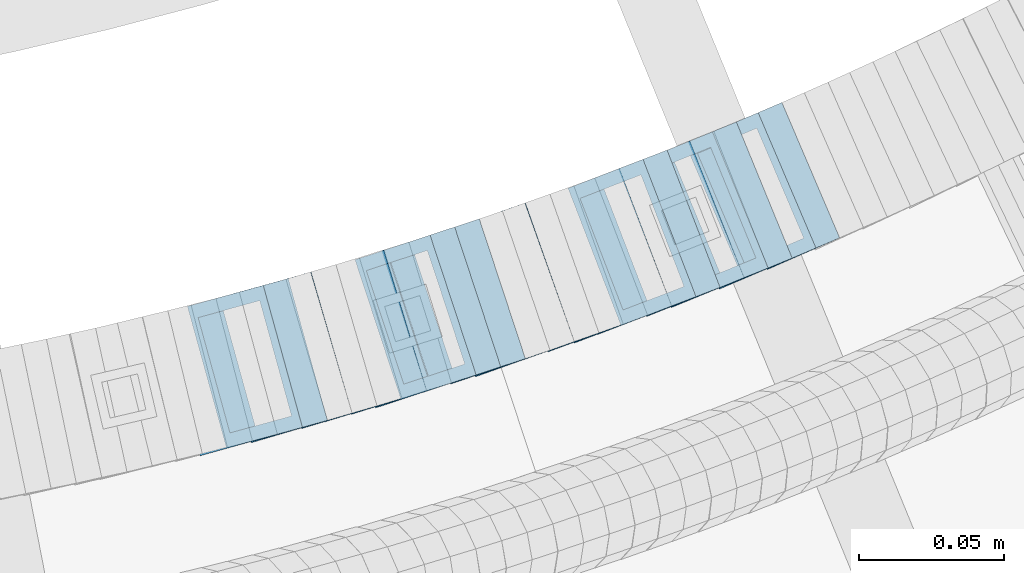
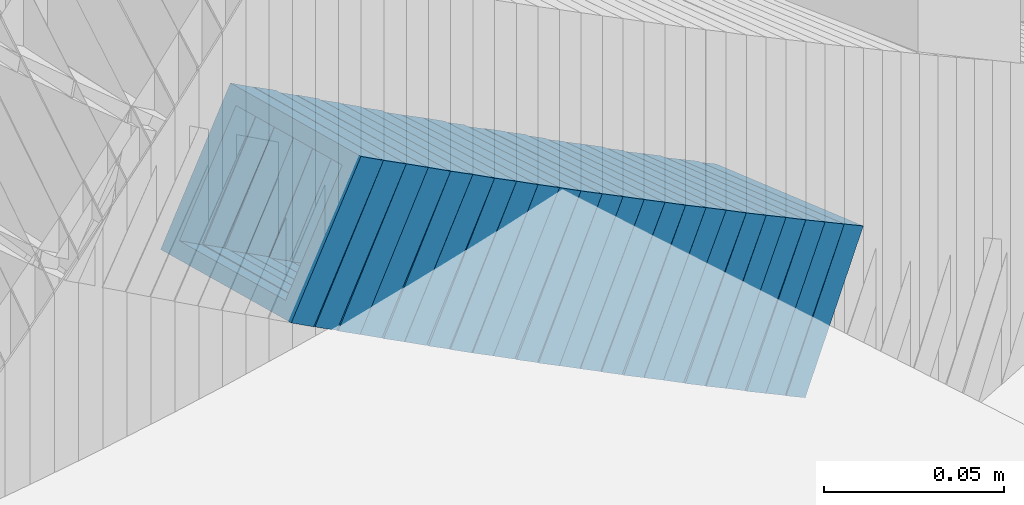
# One storey, part 712 of 975: 24 members.
"""IFC2X3 building model written with IfcOpenShell, lengths in millimetres."""

from ifc_helpers import new_model, si_unit, frame, origin_with_axes, place, context, subcontext, project, spatial, faceted_brep, material, type_object, element, save


model = new_model("IFC2X3")

# Units and contexts
model_context = context("Model", 3, precision=1e-05, world=origin_with_axes())
body_context = subcontext(model_context, "Body", "Model", "MODEL_VIEW")
ifc_project = project(units=[si_unit("LENGTHUNIT", "METRE", prefix="MILLI"), si_unit("AREAUNIT", "SQUARE_METRE"), si_unit("VOLUMEUNIT", "CUBIC_METRE"), si_unit("MASSUNIT", "GRAM", prefix="KILO"), si_unit("TIMEUNIT", "SECOND"), si_unit("PLANEANGLEUNIT", "RADIAN"), si_unit("SOLIDANGLEUNIT", "STERADIAN"), si_unit("THERMODYNAMICTEMPERATUREUNIT", "DEGREE_CELSIUS"), si_unit("LUMINOUSINTENSITYUNIT", "LUMEN")], contexts=[model_context])

# Site, building, storey
site_placement = place(None, origin_with_axes())
site = spatial("IfcSite", under=ifc_project, at=site_placement, CompositionType="ELEMENT")
building_placement = place(site_placement, origin_with_axes())
building = spatial("IfcBuilding", under=site, at=building_placement, Name="Undefined", CompositionType="ELEMENT")
storey_placement = place(building_placement, origin_with_axes())
storey = spatial("IfcBuildingStorey", under=building, at=storey_placement, Name="Undefined", CompositionType="ELEMENT", Elevation=0.0)

# Members
ifc_material = material()
member_type = type_object("IfcMemberType", Name="HSS2X2X.188_TUBES", PredefinedType="NOTDEFINED")
member_1_placement = place(storey_placement, frame((35093.8103006779, 2053.41983135916, 3047.19961551129), z_axis=(0.268798967764145, -0.963196301347202, 2.08201072382508e-10), x_axis=(-0.80773431354215, -0.22541422687225, 0.544751048691214)))
element("IfcMember", 1, at=member_1_placement, inside=storey, type_object=member_type, material=ifc_material, Name="WALL", ObjectType="HSS2X2X.188_TUBES", context=body_context, shape_type="Brep", body=[
    faceted_brep([(0.0, 20.6374999999753, -20.6375000000298), (0.0, -20.6375000000153, -20.6375000000153), (10.648004507897, -20.6374999999862, -20.637499999968), (10.6480045078188, 20.6374999999771, -20.6375000000808), (0.0, -20.6374999999825, 20.6375000000335), (10.6480045079406, -20.6374999999698, 20.6375000001062), (0.0, 20.6375000000116, 20.6375000000189), (10.6480045078679, 20.6374999999935, 20.6375000000007), (0.0, 25.3999999999724, -25.4000000000342), (0.0, 25.400000000016, 25.4000000000196), (10.6480045078661, 25.3999999999905, 25.4000000000015), (10.648004507806, 25.3999999999705, -25.4000000000997), (0.0, -25.399999999976, 25.4000000000378), (10.6480045079552, -25.3999999999633, 25.4000000001288), (0.0, -25.400000000016, -25.4000000000196), (10.6480045078988, -25.3999999999814, -25.3999999999651)], [[[0, 1, 2, 3]], [[1, 4, 5, 2]], [[4, 6, 7, 5]], [[6, 0, 3, 7]], [[8, 9, 10, 11]], [[9, 12, 13, 10]], [[12, 14, 15, 13]], [[14, 8, 11, 15]], [[13, 15, 11, 10], [5, 7, 3, 2]], [[14, 12, 9, 8], [6, 4, 1, 0]]]),
])
member_2_placement = place(storey_placement, frame((35102.8355591383, 2055.95242509423, 3041.32460536502), z_axis=(0.265928998080432, -0.963992618218593, -1.22554411063902e-11), x_axis=(-0.815044169709422, -0.224839770919824, 0.533994455809609)))
element("IfcMember", 2, at=member_2_placement, inside=storey, type_object=member_type, material=ifc_material, Name="WALL", ObjectType="HSS2X2X.188_TUBES", context=body_context, shape_type="Brep", body=[
    faceted_brep([(0.0, 20.6374999999753, -20.6375000000298), (0.0, -20.6375000000153, -20.6375000000153), (10.6709887076922, -20.6374999999844, -20.6374999999825), (10.6709887076995, 20.6375000000171, -20.6374999999753), (0.0, -20.6374999999825, 20.6375000000335), (10.6709887076922, -20.6374999999971, 20.6375000000153), (0.0, 20.6375000000116, 20.6375000000189), (10.6709887076941, 20.6375000000025, 20.6375000000189), (0.0, 25.3999999999724, -25.4000000000342), (0.0, 25.400000000016, 25.4000000000196), (10.6709887076959, 25.3999999999996, 25.4000000000233), (10.6709887077013, 25.4000000000178, -25.3999999999724), (0.0, -25.399999999976, 25.4000000000378), (10.6709887076904, -25.3999999999978, 25.400000000016), (0.0, -25.400000000016, -25.4000000000196), (10.6709887076959, -25.3999999999796, -25.3999999999796)], [[[0, 1, 2, 3]], [[1, 4, 5, 2]], [[4, 6, 7, 5]], [[6, 0, 3, 7]], [[8, 9, 10, 11]], [[9, 12, 13, 10]], [[12, 14, 15, 13]], [[14, 8, 11, 15]], [[13, 15, 11, 10], [5, 7, 3, 2]], [[14, 12, 9, 8], [6, 4, 1, 0]]]),
])
member_3_placement = place(storey_placement, frame((35110.8140978332, 2058.06413469108, 3035.73875214641), z_axis=(0.282166323550089, -0.959365501701112, 2.23427377932239e-10), x_axis=(-0.806820640951415, -0.237300187985733, 0.541044428967422)))
element("IfcMember", 3, at=member_3_placement, inside=storey, type_object=member_type, material=ifc_material, Name="WALL", ObjectType="HSS2X2X.188_TUBES", context=body_context, shape_type="Brep", body=[
    faceted_brep([(0.0, 20.6374999999753, -20.6375000000298), (0.0, -20.6375000000153, -20.6375000000153), (10.5422957651572, -20.6374999999771, -20.6374999999534), (10.5422957651481, 20.6375000000153, -20.6374999999789), (0.0, -20.6374999999825, 20.6375000000335), (10.5422957651535, -20.6374999999971, 20.6375000000298), (0.0, 20.6375000000116, 20.6375000000189), (10.5422957651444, 20.6374999999971, 20.6375000000044), (0.0, 25.3999999999724, -25.4000000000342), (0.0, 25.400000000016, 25.4000000000196), (10.5422957651426, 25.3999999999924, 25.3999999999905), (10.5422957651463, 25.4000000000178, -25.3999999999833), (0.0, -25.399999999976, 25.4000000000378), (10.5422957651499, -25.3999999999996, 25.4000000000269), (0.0, -25.400000000016, -25.4000000000196), (10.5422957651554, -25.3999999999742, -25.3999999999469)], [[[0, 1, 2, 3]], [[1, 4, 5, 2]], [[4, 6, 7, 5]], [[6, 0, 3, 7]], [[8, 9, 10, 11]], [[9, 12, 13, 10]], [[12, 14, 15, 13]], [[14, 8, 11, 15]], [[13, 15, 11, 10], [5, 7, 3, 2]], [[14, 12, 9, 8], [6, 4, 1, 0]]]),
])
member_4_placement = place(storey_placement, frame((35119.4169723431, 2060.61019087342, 3029.98028193762), z_axis=(0.279142363058039, -0.960249728532309, -1.20638560474617e-10), x_axis=(-0.805994231967301, -0.234300648990504, 0.543577504977965)))
element("IfcMember", 4, at=member_4_placement, inside=storey, type_object=member_type, material=ifc_material, Name="WALL", ObjectType="HSS2X2X.188_TUBES", context=body_context, shape_type="Brep", body=[
    faceted_brep([(0.0, 20.6374999999753, -20.6375000000298), (0.0, -20.6375000000153, -20.6375000000153), (10.6709887076922, -20.6374999999844, -20.6374999999825), (10.6709887076995, 20.6375000000171, -20.6374999999753), (0.0, -20.6374999999825, 20.6375000000335), (10.6709887076922, -20.6374999999971, 20.6375000000153), (0.0, 20.6375000000116, 20.6375000000189), (10.6709887076941, 20.6375000000025, 20.6375000000189), (0.0, 25.3999999999724, -25.4000000000342), (0.0, 25.400000000016, 25.4000000000196), (10.6709887076959, 25.3999999999996, 25.4000000000233), (10.6709887077013, 25.4000000000178, -25.3999999999724), (0.0, -25.399999999976, 25.4000000000378), (10.6709887076904, -25.3999999999978, 25.400000000016), (0.0, -25.400000000016, -25.4000000000196), (10.6709887076959, -25.3999999999796, -25.3999999999796)], [[[0, 1, 2, 3]], [[1, 4, 5, 2]], [[4, 6, 7, 5]], [[6, 0, 3, 7]], [[8, 9, 10, 11]], [[9, 12, 13, 10]], [[12, 14, 15, 13]], [[14, 8, 11, 15]], [[13, 15, 11, 10], [5, 7, 3, 2]], [[14, 12, 9, 8], [6, 4, 1, 0]]]),
])
member_5_placement = place(storey_placement, frame((35127.9898472608, 2063.04934262772, 3024.1522421416), z_axis=(0.289389501515281, -0.957211427226366, -2.71364569925936e-10), x_axis=(-0.808269248899405, -0.244360470969586, 0.535713338933346)))
element("IfcMember", 5, at=member_5_placement, inside=storey, type_object=member_type, material=ifc_material, Name="WALL", ObjectType="HSS2X2X.188_TUBES", context=body_context, shape_type="Brep", body=[
    faceted_brep([(0.0, 20.6374999999753, -20.6375000000298), (0.0, -20.6375000000153, -20.6375000000153), (10.6395488625676, -20.6374999999771, -20.6374999999716), (10.6395488625531, 20.6374999999916, -20.6375000000189), (0.0, -20.6374999999825, 20.6375000000335), (10.6395488625731, -20.6374999999844, 20.6375000000153), (0.0, 20.6375000000116, 20.6375000000189), (10.6395488625585, 20.6374999999825, 20.637499999968), (0.0, 25.3999999999724, -25.4000000000342), (0.0, 25.400000000016, 25.4000000000196), (10.6395488625567, 25.3999999999778, 25.3999999999614), (10.6395488625494, 25.3999999999887, -25.4000000000233), (0.0, -25.399999999976, 25.4000000000378), (10.6395488625749, -25.3999999999851, 25.400000000016), (0.0, -25.400000000016, -25.4000000000196), (10.6395488625658, -25.399999999976, -25.3999999999687)], [[[0, 1, 2, 3]], [[1, 4, 5, 2]], [[4, 6, 7, 5]], [[6, 0, 3, 7]], [[8, 9, 10, 11]], [[9, 12, 13, 10]], [[12, 14, 15, 13]], [[14, 8, 11, 15]], [[13, 15, 11, 10], [5, 7, 3, 2]], [[14, 12, 9, 8], [6, 4, 1, 0]]]),
])
member_6_placement = place(storey_placement, frame((35136.1624697946, 2065.50301785137, 3018.52795959015), z_axis=(0.292504341929598, -0.956264194640965, -2.45950104726944e-11), x_axis=(-0.800853960868517, -0.244967093959789, 0.546465054910288)))
element("IfcMember", 6, at=member_6_placement, inside=storey, type_object=member_type, material=ifc_material, Name="WALL", ObjectType="HSS2X2X.188_TUBES", context=body_context, shape_type="Brep", body=[
    faceted_brep([(0.0, 20.6374999999753, -20.6375000000298), (0.0, -20.6375000000153, -20.6375000000153), (10.6061303028146, -20.6374999999571, -20.6374999999643), (10.6061303027491, 20.6374999999971, -20.6375000000007), (0.0, -20.6374999999825, 20.6375000000335), (10.6061303027855, -20.6374999999825, 20.6375000000116), (0.0, 20.6375000000116, 20.6375000000189), (10.6061303027236, 20.637499999968, 20.6374999999716), (0.0, 25.3999999999724, -25.4000000000342), (0.0, 25.400000000016, 25.4000000000196), (10.6061303027163, 25.3999999999651, 25.3999999999651), (10.6061303027454, 25.3999999999942, -25.4000000000051), (0.0, -25.399999999976, 25.4000000000378), (10.6061303027891, -25.3999999999796, 25.4000000000124), (0.0, -25.400000000016, -25.4000000000196), (10.6061303028182, -25.3999999999505, -25.3999999999542)], [[[0, 1, 2, 3]], [[1, 4, 5, 2]], [[4, 6, 7, 5]], [[6, 0, 3, 7]], [[8, 9, 10, 11]], [[9, 12, 13, 10]], [[12, 14, 15, 13]], [[14, 8, 11, 15]], [[13, 15, 11, 10], [5, 7, 3, 2]], [[14, 12, 9, 8], [6, 4, 1, 0]]]),
])
for number, where, z_axis, x_axis, name in (
    (7, (35144.9049059315, 2068.14132858862, 3012.63213827413), (0.299538105904554, -0.954084337525311, -3.23302629112732e-11), (-0.80638388319023, -0.253167033059731, 0.534463737126083), "WALL"),
    (8, (35152.8976331412, 2070.57663441599, 3006.98499966883), (0.312873574955811, -0.949794781041868, 3.56890268449206e-11), (-0.797042365334178, -0.262555132110099, 0.543864202228044), "WALL"),
):
    element("IfcMember", number, at=place(storey_placement, frame(where, z_axis=z_axis, x_axis=x_axis)), inside=storey, type_object=member_type, material=ifc_material, Name=name, ObjectType="HSS2X2X.188_TUBES", context=body_context, shape_type="Brep", body=[
        faceted_brep([(0.0, 20.6374999999753, -20.6375000000298), (0.0, -20.6375000000153, -20.6375000000153), (10.6625512894789, -20.6374999999625, -20.6374999999389), (10.6625512893879, 20.6374999999789, -20.6375000000371), (0.0, -20.6374999999825, 20.6375000000335), (10.6625512894352, -20.6374999999989, 20.6375000000153), (0.0, 20.6375000000116, 20.6375000000189), (10.6625512893443, 20.6374999999443, 20.6374999999134), (0.0, 25.3999999999724, -25.4000000000342), (0.0, 25.400000000016, 25.4000000000196), (10.6625512893297, 25.3999999999342, 25.3999999998996), (10.6625512893916, 25.399999999976, -25.4000000000415), (0.0, -25.399999999976, 25.4000000000378), (10.6625512894389, -25.399999999996, 25.400000000016), (0.0, -25.400000000016, -25.4000000000196), (10.6625512894971, -25.3999999999523, -25.3999999999214)], [[[0, 1, 2, 3]], [[1, 4, 5, 2]], [[4, 6, 7, 5]], [[6, 0, 3, 7]], [[8, 9, 10, 11]], [[9, 12, 13, 10]], [[12, 14, 15, 13]], [[14, 8, 11, 15]], [[13, 15, 11, 10], [5, 7, 3, 2]], [[14, 12, 9, 8], [6, 4, 1, 0]]]),
    ])
member_7_placement = place(storey_placement, frame((35161.5581600231, 2073.42951385945, 3001.17641035378), z_axis=(0.312873574955811, -0.949794781041868, 3.56890268449206e-11), x_axis=(-0.801102899019698, -0.263892720006474, 0.537210180013205)))
element("IfcMember", 9, at=member_7_placement, inside=storey, type_object=member_type, material=ifc_material, Name="WALL", ObjectType="HSS2X2X.188_TUBES", context=body_context, shape_type="Brep", body=[
    faceted_brep([(0.0, 20.6374999999753, -20.6375000000298), (0.0, -20.6375000000153, -20.6375000000153), (10.6061303028146, -20.6374999999571, -20.6374999999643), (10.6061303027491, 20.6374999999971, -20.6375000000007), (0.0, -20.6374999999825, 20.6375000000335), (10.6061303027855, -20.6374999999825, 20.6375000000116), (0.0, 20.6375000000116, 20.6375000000189), (10.6061303027236, 20.637499999968, 20.6374999999716), (0.0, 25.3999999999724, -25.4000000000342), (0.0, 25.400000000016, 25.4000000000196), (10.6061303027163, 25.3999999999651, 25.3999999999651), (10.6061303027454, 25.3999999999942, -25.4000000000051), (0.0, -25.399999999976, 25.4000000000378), (10.6061303027891, -25.3999999999796, 25.4000000000124), (0.0, -25.400000000016, -25.4000000000196), (10.6061303028182, -25.3999999999505, -25.3999999999542)], [[[0, 1, 2, 3]], [[1, 4, 5, 2]], [[4, 6, 7, 5]], [[6, 0, 3, 7]], [[8, 9, 10, 11]], [[9, 12, 13, 10]], [[12, 14, 15, 13]], [[14, 8, 11, 15]], [[13, 15, 11, 10], [5, 7, 3, 2]], [[14, 12, 9, 8], [6, 4, 1, 0]]]),
])
member_8_placement = place(storey_placement, frame((35169.8976331412, 2076.17663441599, 2995.48499966883), z_axis=(0.312873574955811, -0.949794781041868, 3.56890268449206e-11), x_axis=(-0.797042365334178, -0.262555132110099, 0.543864202228044)))
element("IfcMember", 10, at=member_8_placement, inside=storey, type_object=member_type, material=ifc_material, Name="WALL", ObjectType="HSS2X2X.188_TUBES", context=body_context, shape_type="Brep", body=[
    faceted_brep([(0.0, 20.6374999999753, -20.6375000000298), (0.0, -20.6375000000153, -20.6375000000153), (10.6625512894789, -20.6374999999625, -20.6374999999389), (10.6625512893879, 20.6374999999789, -20.6375000000371), (0.0, -20.6374999999825, 20.6375000000335), (10.6625512894352, -20.6374999999989, 20.6375000000153), (0.0, 20.6375000000116, 20.6375000000189), (10.6625512893443, 20.6374999999443, 20.6374999999134), (0.0, 25.3999999999724, -25.4000000000342), (0.0, 25.400000000016, 25.4000000000196), (10.6625512893297, 25.3999999999342, 25.3999999998996), (10.6625512893916, 25.399999999976, -25.4000000000415), (0.0, -25.399999999976, 25.4000000000378), (10.6625512894389, -25.399999999996, 25.400000000016), (0.0, -25.400000000016, -25.4000000000196), (10.6625512894971, -25.3999999999523, -25.3999999999214)], [[[0, 1, 2, 3]], [[1, 4, 5, 2]], [[4, 6, 7, 5]], [[6, 0, 3, 7]], [[8, 9, 10, 11]], [[9, 12, 13, 10]], [[12, 14, 15, 13]], [[14, 8, 11, 15]], [[13, 15, 11, 10], [5, 7, 3, 2]], [[14, 12, 9, 8], [6, 4, 1, 0]]]),
])
member_9_placement = place(storey_placement, frame((35178.381915698, 2078.91841271264, 2989.6545311128), z_axis=(0.322900627824725, -0.946432873768868, 5.79188963456545e-11), x_axis=(-0.799082549180622, -0.272628164061617, 0.535855357121109)))
element("IfcMember", 11, at=member_9_placement, inside=storey, type_object=member_type, material=ifc_material, Name="WALL", ObjectType="HSS2X2X.188_TUBES", context=body_context, shape_type="Brep", body=[
    faceted_brep([(0.0, 20.6374999999753, -20.6375000000298), (0.0, -20.6375000000153, -20.6375000000153), (10.6395488625676, -20.6374999999771, -20.6374999999716), (10.6395488625531, 20.6374999999916, -20.6375000000189), (0.0, -20.6374999999825, 20.6375000000335), (10.6395488625731, -20.6374999999844, 20.6375000000153), (0.0, 20.6375000000116, 20.6375000000189), (10.6395488625585, 20.6374999999825, 20.637499999968), (0.0, 25.3999999999724, -25.4000000000342), (0.0, 25.400000000016, 25.4000000000196), (10.6395488625567, 25.3999999999778, 25.3999999999614), (10.6395488625494, 25.3999999999887, -25.4000000000233), (0.0, -25.399999999976, 25.4000000000378), (10.6395488625749, -25.3999999999851, 25.400000000016), (0.0, -25.400000000016, -25.4000000000196), (10.6395488625658, -25.399999999976, -25.3999999999687)], [[[0, 1, 2, 3]], [[1, 4, 5, 2]], [[4, 6, 7, 5]], [[6, 0, 3, 7]], [[8, 9, 10, 11]], [[9, 12, 13, 10]], [[12, 14, 15, 13]], [[14, 8, 11, 15]], [[13, 15, 11, 10], [5, 7, 3, 2]], [[14, 12, 9, 8], [6, 4, 1, 0]]]),
])
member_10_placement = place(storey_placement, frame((35186.4417317939, 2081.5939764214, 2983.99697428563), z_axis=(0.336336397174964, -0.941741911531692, -2.05948254006216e-10), x_axis=(-0.793548281859535, -0.283410100949865, 0.538479190904688)))
element("IfcMember", 12, at=member_10_placement, inside=storey, type_object=member_type, material=ifc_material, Name="WALL", ObjectType="HSS2X2X.188_TUBES", context=body_context, shape_type="Brep", body=[
    faceted_brep([(0.0, 20.6374999999753, -20.6375000000298), (0.0, -20.6375000000153, -20.6375000000153), (10.5948100501191, -20.6375000000335, -20.6375000000844), (10.5948100501555, 20.6374999999971, -20.6375000000116), (0.0, -20.6374999999825, 20.6375000000335), (10.5948100501446, -20.6375000000098, 20.6374999999571), (0.0, 20.6375000000116, 20.6375000000189), (10.5948100501828, 20.6375000000189, 20.6375000000298), (0.0, 25.3999999999724, -25.4000000000342), (0.0, 25.400000000016, 25.4000000000196), (10.5948100501919, 25.4000000000251, 25.4000000000451), (10.5948100501591, 25.3999999999978, -25.4000000000051), (0.0, -25.399999999976, 25.4000000000378), (10.5948100501482, -25.4000000000106, 25.3999999999578), (0.0, -25.400000000016, -25.4000000000196), (10.5948100501118, -25.4000000000378, -25.400000000096)], [[[0, 1, 2, 3]], [[1, 4, 5, 2]], [[4, 6, 7, 5]], [[6, 0, 3, 7]], [[8, 9, 10, 11]], [[9, 12, 13, 10]], [[12, 14, 15, 13]], [[14, 8, 11, 15]], [[13, 15, 11, 10], [5, 7, 3, 2]], [[14, 12, 9, 8], [6, 4, 1, 0]]]),
])
member_11_placement = place(storey_placement, frame((35194.9509177851, 2084.65152601956, 2978.23985056992), z_axis=(0.332820117897747, -0.942990333525498, -3.95698407373857e-11), x_axis=(-0.793008442806512, -0.279885332931725, 0.541111642867984)))
element("IfcMember", 13, at=member_11_placement, inside=storey, type_object=member_type, material=ifc_material, Name="WALL", ObjectType="HSS2X2X.188_TUBES", context=body_context, shape_type="Brep", body=[
    faceted_brep([(0.0, 20.6374999999753, -20.6375000000298), (0.0, -20.6375000000153, -20.6375000000153), (10.7247377590011, -20.6375000000189, -20.6375000000589), (10.7247377589938, 20.6374999999844, -20.6375000000698), (0.0, -20.6374999999825, 20.6375000000335), (10.7247377590484, -20.6374999999771, 20.6375000000517), (0.0, 20.6375000000116, 20.6375000000189), (10.7247377590447, 20.6375000000262, 20.6375000000407), (0.0, 25.3999999999724, -25.4000000000342), (0.0, 25.400000000016, 25.4000000000196), (10.7247377590484, 25.4000000000342, 25.400000000056), (10.7247377589902, 25.3999999999778, -25.4000000000851), (0.0, -25.399999999976, 25.4000000000378), (10.7247377590556, -25.3999999999724, 25.4000000000633), (0.0, -25.400000000016, -25.4000000000196), (10.7247377589938, -25.4000000000251, -25.4000000000742)], [[[0, 1, 2, 3]], [[1, 4, 5, 2]], [[4, 6, 7, 5]], [[6, 0, 3, 7]], [[8, 9, 10, 11]], [[9, 12, 13, 10]], [[12, 14, 15, 13]], [[14, 8, 11, 15]], [[13, 15, 11, 10], [5, 7, 3, 2]], [[14, 12, 9, 8], [6, 4, 1, 0]]]),
])
member_12_placement = place(storey_placement, frame((35203.3417317939, 2087.59397642139, 2972.49697428563), z_axis=(0.336336397174964, -0.941741911531692, -2.05948254006216e-10), x_axis=(-0.793548281859535, -0.283410100949865, 0.538479190904688)))
element("IfcMember", 14, at=member_12_placement, inside=storey, type_object=member_type, material=ifc_material, Name="WALL", ObjectType="HSS2X2X.188_TUBES", context=body_context, shape_type="Brep", body=[
    faceted_brep([(0.0, 20.6374999999753, -20.6375000000298), (0.0, -20.6375000000153, -20.6375000000153), (10.5948100501191, -20.6375000000335, -20.6375000000844), (10.5948100501555, 20.6374999999971, -20.6375000000116), (0.0, -20.6374999999825, 20.6375000000335), (10.5948100501446, -20.6375000000098, 20.6374999999571), (0.0, 20.6375000000116, 20.6375000000189), (10.5948100501828, 20.6375000000189, 20.6375000000298), (0.0, 25.3999999999724, -25.4000000000342), (0.0, 25.400000000016, 25.4000000000196), (10.5948100501919, 25.4000000000251, 25.4000000000451), (10.5948100501591, 25.3999999999978, -25.4000000000051), (0.0, -25.399999999976, 25.4000000000378), (10.5948100501482, -25.4000000000106, 25.3999999999578), (0.0, -25.400000000016, -25.4000000000196), (10.5948100501118, -25.4000000000378, -25.400000000096)], [[[0, 1, 2, 3]], [[1, 4, 5, 2]], [[4, 6, 7, 5]], [[6, 0, 3, 7]], [[8, 9, 10, 11]], [[9, 12, 13, 10]], [[12, 14, 15, 13]], [[14, 8, 11, 15]], [[13, 15, 11, 10], [5, 7, 3, 2]], [[14, 12, 9, 8], [6, 4, 1, 0]]]),
])
member_13_placement = place(storey_placement, frame((35211.4159478194, 2090.42190428812, 2966.78185329332), z_axis=(0.346222870204496, -0.938152292619573, -2.09595327760326e-10), x_axis=(-0.787388512015476, -0.290583856005715, 0.543673021010703)))
element("IfcMember", 15, at=member_13_placement, inside=storey, type_object=member_type, material=ifc_material, Name="WALL", ObjectType="HSS2X2X.188_TUBES", context=body_context, shape_type="Brep", body=[
    faceted_brep([(0.0, 20.6374999999753, -20.6375000000298), (0.0, -20.6375000000153, -20.6375000000153), (10.6709887076922, -20.6374999999844, -20.6374999999825), (10.6709887076995, 20.6375000000171, -20.6374999999753), (0.0, -20.6374999999825, 20.6375000000335), (10.6709887076922, -20.6374999999971, 20.6375000000153), (0.0, 20.6375000000116, 20.6375000000189), (10.6709887076941, 20.6375000000025, 20.6375000000189), (0.0, 25.3999999999724, -25.4000000000342), (0.0, 25.400000000016, 25.4000000000196), (10.6709887076959, 25.3999999999996, 25.4000000000233), (10.6709887077013, 25.4000000000178, -25.3999999999724), (0.0, -25.399999999976, 25.4000000000378), (10.6709887076904, -25.3999999999978, 25.400000000016), (0.0, -25.400000000016, -25.4000000000196), (10.6709887076959, -25.3999999999796, -25.3999999999796)], [[[0, 1, 2, 3]], [[1, 4, 5, 2]], [[4, 6, 7, 5]], [[6, 0, 3, 7]], [[8, 9, 10, 11]], [[9, 12, 13, 10]], [[12, 14, 15, 13]], [[14, 8, 11, 15]], [[13, 15, 11, 10], [5, 7, 3, 2]], [[14, 12, 9, 8], [6, 4, 1, 0]]]),
])
member_14_placement = place(storey_placement, frame((35219.811753653, 2093.46755807686, 2960.94919433073), z_axis=(0.355995327441539, -0.934487734986282, 3.27830093738158e-10), x_axis=(-0.789193496498296, -0.300645141189797, 0.535524158338129)))
element("IfcMember", 16, at=member_14_placement, inside=storey, type_object=member_type, material=ifc_material, Name="WALL", ObjectType="HSS2X2X.188_TUBES", context=body_context, shape_type="Brep", body=[
    faceted_brep([(0.0, 20.6374999999753, -20.6375000000298), (0.0, -20.6375000000153, -20.6375000000153), (10.6395488625676, -20.6374999999771, -20.6374999999716), (10.6395488625531, 20.6374999999916, -20.6375000000189), (0.0, -20.6374999999825, 20.6375000000335), (10.6395488625731, -20.6374999999844, 20.6375000000153), (0.0, 20.6375000000116, 20.6375000000189), (10.6395488625585, 20.6374999999825, 20.637499999968), (0.0, 25.3999999999724, -25.4000000000342), (0.0, 25.400000000016, 25.4000000000196), (10.6395488625567, 25.3999999999778, 25.3999999999614), (10.6395488625494, 25.3999999999887, -25.4000000000233), (0.0, -25.399999999976, 25.4000000000378), (10.6395488625749, -25.3999999999851, 25.400000000016), (0.0, -25.400000000016, -25.4000000000196), (10.6395488625658, -25.399999999976, -25.3999999999687)], [[[0, 1, 2, 3]], [[1, 4, 5, 2]], [[4, 6, 7, 5]], [[6, 0, 3, 7]], [[8, 9, 10, 11]], [[9, 12, 13, 10]], [[12, 14, 15, 13]], [[14, 8, 11, 15]], [[13, 15, 11, 10], [5, 7, 3, 2]], [[14, 12, 9, 8], [6, 4, 1, 0]]]),
])
member_15_placement = place(storey_placement, frame((35227.9417252364, 2096.54388125898, 2955.31381643287), z_axis=(0.359732267798929, -0.933055569354923, 2.02026967599522e-10), x_axis=(-0.785610145271087, -0.302885839104528, 0.539515401186182)))
element("IfcMember", 17, at=member_15_placement, inside=storey, type_object=member_type, material=ifc_material, Name="WALL", ObjectType="HSS2X2X.188_TUBES", context=body_context, shape_type="Brep", body=[
    faceted_brep([(0.0, 20.6374999999753, -20.6375000000298), (0.0, -20.6375000000153, -20.6375000000153), (10.5744976239494, -20.6375000000207, -20.6375000000335), (10.5744976239657, 20.6375000000098, -20.637500000008), (0.0, -20.6374999999825, 20.6375000000335), (10.5744976239639, -20.6375000000244, 20.6374999999753), (0.0, 20.6375000000116, 20.6375000000189), (10.5744976239803, 20.6374999999989, 20.6374999999935), (0.0, 25.3999999999724, -25.4000000000342), (0.0, 25.400000000016, 25.4000000000196), (10.5744976239857, 25.4000000000051, 25.4000000000015), (10.5744976239675, 25.4000000000124, -25.4000000000051), (0.0, -25.399999999976, 25.4000000000378), (10.5744976239639, -25.4000000000287, 25.3999999999724), (0.0, -25.400000000016, -25.4000000000196), (10.5744976239494, -25.4000000000215, -25.4000000000378)], [[[0, 1, 2, 3]], [[1, 4, 5, 2]], [[4, 6, 7, 5]], [[6, 0, 3, 7]], [[8, 9, 10, 11]], [[9, 12, 13, 10]], [[12, 14, 15, 13]], [[14, 8, 11, 15]], [[13, 15, 11, 10], [5, 7, 3, 2]], [[14, 12, 9, 8], [6, 4, 1, 0]]]),
])
member_16_placement = place(storey_placement, frame((35236.0839136287, 2099.68303822947, 2949.62314131539), z_axis=(0.359732267798929, -0.933055569354923, 2.02026967599522e-10), x_axis=(-0.781594153680327, -0.301337504876737, 0.546174227776628)))
element("IfcMember", 18, at=member_16_placement, inside=storey, type_object=member_type, material=ifc_material, Name="WALL", ObjectType="HSS2X2X.188_TUBES", context=body_context, shape_type="Brep", body=[
    faceted_brep([(0.0, 20.6374999999753, -20.6375000000298), (0.0, -20.6375000000153, -20.6375000000153), (10.6216759506497, -20.637499999968, -20.6374999999534), (10.6216759506497, 20.6375000000262, -20.6374999999643), (0.0, -20.6374999999825, 20.6375000000335), (10.6216759506169, -20.6374999999935, 20.637500000008), (0.0, 20.6375000000116, 20.6375000000189), (10.6216759506242, 20.6375000000007, 20.6374999999971), (0.0, 25.3999999999724, -25.4000000000342), (0.0, 25.400000000016, 25.4000000000196), (10.6216759506169, 25.3999999999978, 25.3999999999869), (10.6216759506533, 25.4000000000269, -25.3999999999614), (0.0, -25.399999999976, 25.4000000000378), (10.6216759506242, -25.3999999999942, 25.4000000000051), (0.0, -25.400000000016, -25.4000000000196), (10.6216759506569, -25.3999999999614, -25.3999999999432)], [[[0, 1, 2, 3]], [[1, 4, 5, 2]], [[4, 6, 7, 5]], [[6, 0, 3, 7]], [[8, 9, 10, 11]], [[9, 12, 13, 10]], [[12, 14, 15, 13]], [[14, 8, 11, 15]], [[13, 15, 11, 10], [5, 7, 3, 2]], [[14, 12, 9, 8], [6, 4, 1, 0]]]),
])
member_17_placement = place(storey_placement, frame((35244.3837621263, 2102.82851621578, 2943.78841234493), z_axis=(0.36945957289169, -0.929246804674996, -1.23982317745686e-11), x_axis=(-0.783332654127597, -0.31144551305074, 0.537951341087626)))
element("IfcMember", 19, at=member_17_placement, inside=storey, type_object=member_type, material=ifc_material, Name="WALL", ObjectType="HSS2X2X.188_TUBES", context=body_context, shape_type="Brep", body=[
    faceted_brep([(0.0, 20.6374999999753, -20.6375000000298), (0.0, -20.6375000000153, -20.6375000000153), (10.6004716875832, -20.6375000000153, -20.6375000000553), (10.6004716875814, 20.6374999999898, -20.6375000000444), (0.0, -20.6374999999825, 20.6375000000335), (10.6004716876068, -20.6375000000044, 20.6374999999862), (0.0, 20.6375000000116, 20.6375000000189), (10.6004716876032, 20.6374999999989, 20.6374999999971), (0.0, 25.3999999999724, -25.4000000000342), (0.0, 25.400000000016, 25.4000000000196), (10.600471687605, 25.4000000000015, 25.4000000000051), (10.6004716875814, 25.3999999999869, -25.4000000000487), (0.0, -25.399999999976, 25.4000000000378), (10.6004716876068, -25.4000000000015, 25.3999999999905), (0.0, -25.400000000016, -25.4000000000196), (10.6004716875814, -25.4000000000178, -25.4000000000669)], [[[0, 1, 2, 3]], [[1, 4, 5, 2]], [[4, 6, 7, 5]], [[6, 0, 3, 7]], [[8, 9, 10, 11]], [[9, 12, 13, 10]], [[12, 14, 15, 13]], [[14, 8, 11, 15]], [[13, 15, 11, 10], [5, 7, 3, 2]], [[14, 12, 9, 8], [6, 4, 1, 0]]]),
])
member_18_placement = place(storey_placement, frame((35252.5302787694, 2106.01413837727, 2938.06256359731), z_axis=(0.379066925584048, -0.925369259230205, -2.88005594484275e-10), x_axis=(-0.781005694706527, -0.319930043879771, 0.536353308798466)))
element("IfcMember", 20, at=member_18_placement, inside=storey, type_object=member_type, material=ifc_material, Name="WALL", ObjectType="HSS2X2X.188_TUBES", context=body_context, shape_type="Brep", body=[
    faceted_brep([(0.0, 20.6374999999753, -20.6375000000298), (0.0, -20.6375000000153, -20.6375000000153), (10.6348483769107, -20.637499999988, -20.6374999999825), (10.6348483768415, 20.6374999999734, -20.6375000001026), (0.0, -20.6374999999825, 20.6375000000335), (10.6348483769852, -20.6374999999589, 20.6375000001462), (0.0, 20.6375000000116, 20.6375000000189), (10.6348483769161, 20.6375000000044, 20.6375000000226), (0.0, 25.3999999999724, -25.4000000000342), (0.0, 25.400000000016, 25.4000000000196), (10.6348483769179, 25.4000000000015, 25.4000000000233), (10.6348483768288, 25.3999999999669, -25.4000000001324), (0.0, -25.399999999976, 25.4000000000378), (10.6348483769998, -25.3999999999505, 25.4000000001688), (0.0, -25.400000000016, -25.4000000000196), (10.6348483769107, -25.3999999999887, -25.3999999999833)], [[[0, 1, 2, 3]], [[1, 4, 5, 2]], [[4, 6, 7, 5]], [[6, 0, 3, 7]], [[8, 9, 10, 11]], [[9, 12, 13, 10]], [[12, 14, 15, 13]], [[14, 8, 11, 15]], [[13, 15, 11, 10], [5, 7, 3, 2]], [[14, 12, 9, 8], [6, 4, 1, 0]]]),
])
member_19_placement = place(storey_placement, frame((35260.6739238743, 2109.35008938411, 2932.37087936196), z_axis=(0.379066925584048, -0.925369259230205, -2.88005594484275e-10), x_axis=(-0.777059549860007, -0.318313550942635, 0.543005468902159)))
element("IfcMember", 21, at=member_19_placement, inside=storey, type_object=member_type, material=ifc_material, Name="WALL", ObjectType="HSS2X2X.188_TUBES", context=body_context, shape_type="Brep", body=[
    faceted_brep([(0.0, 20.6374999999753, -20.6375000000298), (0.0, -20.6375000000153, -20.6375000000153), (10.6831643251735, -20.6375000000498, -20.6375000000953), (10.6831643252044, 20.637499999988, -20.6375000000226), (0.0, -20.6374999999825, 20.6375000000335), (10.6831643251935, -20.6375000000135, 20.637499999968), (0.0, 20.6375000000116, 20.6375000000189), (10.6831643252244, 20.6375000000226, 20.6375000000407), (0.0, 25.3999999999724, -25.4000000000342), (0.0, 25.400000000016, 25.4000000000196), (10.6831643252317, 25.4000000000306, 25.4000000000597), (10.6831643252044, 25.3999999999905, -25.4000000000196), (0.0, -25.399999999976, 25.4000000000378), (10.6831643251917, -25.400000000016, 25.3999999999614), (0.0, -25.400000000016, -25.4000000000196), (10.6831643251644, -25.400000000056, -25.4000000001179)], [[[0, 1, 2, 3]], [[1, 4, 5, 2]], [[4, 6, 7, 5]], [[6, 0, 3, 7]], [[8, 9, 10, 11]], [[9, 12, 13, 10]], [[12, 14, 15, 13]], [[14, 8, 11, 15]], [[13, 15, 11, 10], [5, 7, 3, 2]], [[14, 12, 9, 8], [6, 4, 1, 0]]]),
])
for number, where, z_axis, x_axis, name in (
    (22, (35268.710733798, 2112.56398587597, 2926.59970631529), (0.392565197945842, -0.919724178958965, 2.15450199902989e-11), (-0.774896359918611, -0.330748445965264, 0.538647469943422), "WALL"),
    (23, (35276.9107337981, 2116.06398587598, 2920.89970631529), (0.392565197945842, -0.919724178958965, 2.15450199902989e-11), (-0.774896359918611, -0.330748445965264, 0.538647469943422), "WALL"),
):
    element("IfcMember", number, at=place(storey_placement, frame(where, z_axis=z_axis, x_axis=x_axis)), inside=storey, type_object=member_type, material=ifc_material, Name=name, ObjectType="HSS2X2X.188_TUBES", context=body_context, shape_type="Brep", body=[
        faceted_brep([(0.0, 20.6374999999753, -20.6375000000298), (0.0, -20.6375000000153, -20.6375000000153), (10.5806427026419, -20.6374999999607, -20.6374999999316), (10.5806427026473, 20.6375000000444, -20.6374999999207), (0.0, -20.6374999999825, 20.6375000000335), (10.5806427025509, -20.6375000000207, 20.6374999999643), (0.0, 20.6375000000116, 20.6375000000189), (10.5806427025545, 20.6374999999862, 20.6374999999716), (0.0, 25.3999999999724, -25.4000000000342), (0.0, 25.400000000016, 25.4000000000196), (10.5806427025436, 25.3999999999796, 25.3999999999614), (10.5806427026582, 25.4000000000542, -25.3999999999105), (0.0, -25.399999999976, 25.4000000000378), (10.5806427025418, -25.4000000000287, 25.3999999999542), (0.0, -25.400000000016, -25.4000000000196), (10.5806427026528, -25.3999999999542, -25.3999999999178)], [[[0, 1, 2, 3]], [[1, 4, 5, 2]], [[4, 6, 7, 5]], [[6, 0, 3, 7]], [[8, 9, 10, 11]], [[9, 12, 13, 10]], [[12, 14, 15, 13]], [[14, 8, 11, 15]], [[13, 15, 11, 10], [5, 7, 3, 2]], [[14, 12, 9, 8], [6, 4, 1, 0]]]),
    ])
member_20_placement = place(storey_placement, frame((35284.9666923899, 2119.44875576357, 2915.17216906364), z_axis=(0.401990062357494, -0.915644030049788, -1.95609572983813e-10), x_axis=(-0.77245139699793, -0.339125003999077, 0.536947921998561)))
element("IfcMember", 24, at=member_20_placement, inside=storey, type_object=member_type, material=ifc_material, Name="WALL", ObjectType="HSS2X2X.188_TUBES", context=body_context, shape_type="Brep", body=[
    faceted_brep([(0.0, 20.6374999999753, -20.6375000000298), (0.0, -20.6375000000153, -20.6375000000153), (10.6216759506497, -20.637499999968, -20.6374999999534), (10.6216759506497, 20.6375000000262, -20.6374999999643), (0.0, -20.6374999999825, 20.6375000000335), (10.6216759506169, -20.6374999999935, 20.637500000008), (0.0, 20.6375000000116, 20.6375000000189), (10.6216759506242, 20.6375000000007, 20.6374999999971), (0.0, 25.3999999999724, -25.4000000000342), (0.0, 25.400000000016, 25.4000000000196), (10.6216759506169, 25.3999999999978, 25.3999999999869), (10.6216759506533, 25.4000000000269, -25.3999999999614), (0.0, -25.399999999976, 25.4000000000378), (10.6216759506242, -25.3999999999942, 25.4000000000051), (0.0, -25.400000000016, -25.4000000000196), (10.6216759506569, -25.3999999999614, -25.3999999999432)], [[[0, 1, 2, 3]], [[1, 4, 5, 2]], [[4, 6, 7, 5]], [[6, 0, 3, 7]], [[8, 9, 10, 11]], [[9, 12, 13, 10]], [[12, 14, 15, 13]], [[14, 8, 11, 15]], [[13, 15, 11, 10], [5, 7, 3, 2]], [[14, 12, 9, 8], [6, 4, 1, 0]]]),
])

save(model, "model.ifc")
